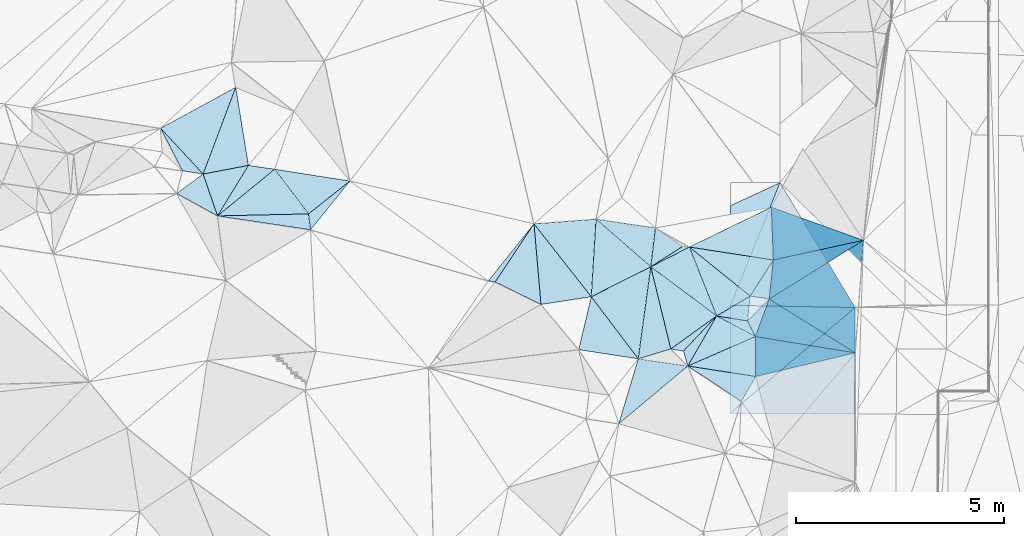
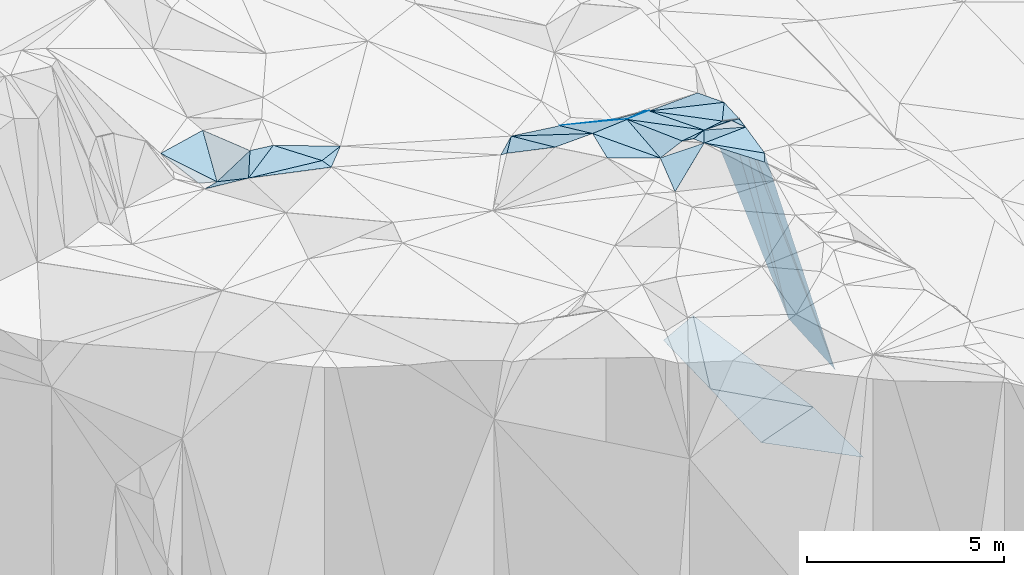
# One storey, part 126 of 275: 45 plates.
"""IFC2X3 building model written with IfcOpenShell, lengths in millimetres."""

from ifc_helpers import new_model, si_unit, frame, origin_with_axes, place, context, subcontext, project, spatial, polyline, outline, extrude, material, type_object, element, save


model = new_model("IFC2X3")

# Units and contexts
model_context = context("Model", 3, precision=1e-05, world=origin_with_axes())
body_context = subcontext(model_context, "Body", "Model", "MODEL_VIEW")
ifc_project = project(units=[si_unit("LENGTHUNIT", "METRE", prefix="MILLI"), si_unit("AREAUNIT", "SQUARE_METRE"), si_unit("VOLUMEUNIT", "CUBIC_METRE"), si_unit("MASSUNIT", "GRAM", prefix="KILO"), si_unit("TIMEUNIT", "SECOND"), si_unit("PLANEANGLEUNIT", "RADIAN"), si_unit("SOLIDANGLEUNIT", "STERADIAN"), si_unit("THERMODYNAMICTEMPERATUREUNIT", "DEGREE_CELSIUS"), si_unit("LUMINOUSINTENSITYUNIT", "LUMEN")], contexts=[model_context])

# Site, building, storey
site_placement = place(None, origin_with_axes())
site = spatial("IfcSite", under=ifc_project, at=site_placement, CompositionType="ELEMENT")
building_placement = place(site_placement, origin_with_axes())
building = spatial("IfcBuilding", under=site, at=building_placement, Name="Undefined", CompositionType="ELEMENT")
storey_placement = place(building_placement, origin_with_axes())
storey = spatial("IfcBuildingStorey", under=building, at=storey_placement, Name="Undefined", CompositionType="ELEMENT", Elevation=0.0)

# Plates
ifc_material = material()
plate_type_1 = type_object("IfcPlateType", PredefinedType="NOTDEFINED")
plate_1_placement = place(storey_placement, frame((-102975.586018144, 104495.460714109, 52899.5563168555), z_axis=(-0.102792415716425, -0.449545724247788, -0.887323143551273), x_axis=(-0.986264291093555, 0.162010960790731, 0.0321744727601088)))
element("IfcPlate", 1, at=plate_1_placement, inside=storey, type_object=plate_type_1, material=ifc_material, Name="00", context=body_context, shape_type="SweptSolid", body=[
    extrude(outline(polyline([(0.0, 0.0), (310.805419921875, -1.55705492943525e-09), (-665.689819335938, 1083.81591796875), (0.0, 0.0)])), frame((-8.85201319254618e-08, 2.18876761149539e-07, -0.5000001331573), z_axis=(0.0, 0.0, 1.0), x_axis=(1.0, 0.0, 0.0)), (0.0, 0.0, 1.0), 1.0),
])
plate_type_2 = type_object("IfcPlateType", PredefinedType="NOTDEFINED")
plate_2_placement = place(storey_placement, frame((-101853.013918243, 105596.241844771, 44075.3131280584), z_axis=(0.00903345976008048, 0.0208217817562675, -0.999742391823642), x_axis=(0.00396946090969268, 0.999774561543775, 0.0208583189648398)))
element("IfcPlate", 2, at=plate_2_placement, inside=storey, type_object=plate_type_2, material=ifc_material, Name="00_PR", context=body_context, shape_type="SweptSolid", body=[
    extrude(outline(polyline([(0.0, 0.0), (2396.74169921875, -1.78988557308912e-09), (2952.07104492188, 1186.95153808594), (0.0, 0.0)])), frame((-8.85201319254618e-08, 2.18876761149539e-07, -0.5000001331573), z_axis=(0.0, 0.0, 1.0), x_axis=(1.0, 0.0, 0.0)), (0.0, 0.0, 1.0), 1.0),
])
plate_type_3 = type_object("IfcPlateType", PredefinedType="NOTDEFINED")
plate_3_placement = place(storey_placement, frame((-112801.754794519, 108865.68811767, 53489.5226366196), z_axis=(-0.276028547930736, -0.111351786075685, -0.954677443152924), x_axis=(0.954406350382673, -0.149203927816331, -0.258547299876455)))
element("IfcPlate", 3, at=plate_3_placement, inside=storey, type_object=plate_type_3, material=ifc_material, Name="00", context=body_context, shape_type="SweptSolid", body=[
    extrude(outline(polyline([(0.0, 0.0), (1895.20446777344, -1.19907781481743e-08), (964.645263671875, 945.388549804688), (0.0, 0.0)])), frame((-8.85201319254618e-08, 2.18876761149539e-07, -0.5000001331573), z_axis=(0.0, 0.0, 1.0), x_axis=(1.0, 0.0, 0.0)), (0.0, 0.0, 1.0), 1.0),
])
plate_type_4 = type_object("IfcPlateType", PredefinedType="NOTDEFINED")
plate_4_placement = place(storey_placement, frame((-98853.4322599263, 105542.573777714, 42488.4351363047), z_axis=(-0.466934488972432, 0.0316275710281692, -0.883726133911922), x_axis=(-0.713003054106607, -0.604596175183413, 0.355091692085634)))
element("IfcPlate", 4, at=plate_4_placement, inside=storey, type_object=plate_type_4, material=ifc_material, Name="00_PR", context=body_context, shape_type="SweptSolid", body=[
    extrude(outline(polyline([(0.0, 0.0), (4220.29296875, 4.04543243348598e-09), (2669.9375, 2095.61401367188), (0.0, 0.0)])), frame((-8.85201319254618e-08, 2.18876761149539e-07, -0.5000001331573), z_axis=(0.0, 0.0, 1.0), x_axis=(1.0, 0.0, 0.0)), (0.0, 0.0, 1.0), 1.0),
])
plate_type_5 = type_object("IfcPlateType", PredefinedType="NOTDEFINED")
plate_5_placement = place(storey_placement, frame((-100654.633836518, 108542.806173912, 44147.576769315), z_axis=(-0.454677368979055, 0.20619155195464, -0.866460347644842), x_axis=(0.465101733246503, -0.774687277284736, -0.428415686155701)))
element("IfcPlate", 5, at=plate_5_placement, inside=storey, type_object=plate_type_5, material=ifc_material, Name="00_PR", context=body_context, shape_type="SweptSolid", body=[
    extrude(outline(polyline([(0.0, 0.0), (3872.7177734375, 2.44217517320067e-08), (1756.04797363281, 2653.27612304688), (0.0, 0.0)])), frame((-8.85201319254618e-08, 2.18876761149539e-07, -0.5000001331573), z_axis=(0.0, 0.0, 1.0), x_axis=(1.0, 0.0, 0.0)), (0.0, 0.0, 1.0), 1.0),
])
plate_type_6 = type_object("IfcPlateType", PredefinedType="NOTDEFINED")
plate_6_placement = place(storey_placement, frame((-102178.92224237, 105339.723863328, 52379.5387091909), z_axis=(-0.125325743835825, -0.364986820406231, -0.922538930810916), x_axis=(0.880317036051721, -0.469736537772759, 0.0662533102446467)))
element("IfcPlate", 6, at=plate_6_placement, inside=storey, type_object=plate_type_6, material=ifc_material, Name="00", context=body_context, shape_type="SweptSolid", body=[
    extrude(outline(polyline([(0.0, 0.0), (1056.55102539063, -2.5465851649642e-11), (-7.0985689163208, 1500.5498046875), (0.0, 0.0)])), frame((-8.85201319254618e-08, 2.18876761149539e-07, -0.5000001331573), z_axis=(0.0, 0.0, 1.0), x_axis=(1.0, 0.0, 0.0)), (0.0, 0.0, 1.0), 1.0),
])
plate_type_7 = type_object("IfcPlateType", PredefinedType="NOTDEFINED")
plate_7_placement = place(storey_placement, frame((-101862.504233261, 102990.985969973, 43987.020784836), z_axis=(-0.447209093222045, 0.00208047033283015, -0.894427022502513), x_axis=(0.713003054110074, 0.604596175166319, -0.355091692107778)))
element("IfcPlate", 7, at=plate_7_placement, inside=storey, type_object=plate_type_7, material=ifc_material, Name="00_PR", context=body_context, shape_type="SweptSolid", body=[
    extrude(outline(polyline([(0.0, 0.0), (4220.29296875, 4.04543243348598e-09), (2665.57739257813, 2035.8525390625), (0.0, 0.0)])), frame((-8.85201319254618e-08, 2.18876761149539e-07, -0.5000001331573), z_axis=(0.0, 0.0, 1.0), x_axis=(1.0, 0.0, 0.0)), (0.0, 0.0, 1.0), 1.0),
])
plate_type_8 = type_object("IfcPlateType", PredefinedType="NOTDEFINED")
plate_8_placement = place(storey_placement, frame((-107503.776969754, 106156.341462293, 53029.5442880401), z_axis=(-0.00890206486978785, -0.411474869166373, -0.911377630450501), x_axis=(-0.98622114632155, 0.154177586781641, -0.0599760142256649)))
element("IfcPlate", 8, at=plate_8_placement, inside=storey, type_object=plate_type_8, material=ifc_material, Name="00", context=body_context, shape_type="SweptSolid", body=[
    extrude(outline(polyline([(0.0, 0.0), (166.733322143555, 1.01863406598568e-09), (-668.1328125, 1670.20910644531), (0.0, 0.0)])), frame((-8.85201319254618e-08, 2.18876761149539e-07, -0.5000001331573), z_axis=(0.0, 0.0, 1.0), x_axis=(1.0, 0.0, 0.0)), (0.0, 0.0, 1.0), 1.0),
])
plate_type_9 = type_object("IfcPlateType", PredefinedType="NOTDEFINED")
plate_9_placement = place(storey_placement, frame((-100864.010065368, 107954.721490375, 51489.5375137855), z_axis=(-0.16714290473019, -0.341427049613979, -0.924927466988762), x_axis=(0.0349844372032486, -0.939587425435422, 0.340516606228254)))
element("IfcPlate", 9, at=plate_9_placement, inside=storey, type_object=plate_type_9, material=ifc_material, Name="00", context=body_context, shape_type="SweptSolid", body=[
    extrude(outline(polyline([(0.0, 0.0), (1350.88854980469, 4.65661287307739e-09), (1073.58959960938, 2038.1376953125), (0.0, 0.0)])), frame((-8.85201319254618e-08, 2.18876761149539e-07, -0.5000001331573), z_axis=(0.0, 0.0, 1.0), x_axis=(1.0, 0.0, 0.0)), (0.0, 0.0, 1.0), 1.0),
])
plate_type_10 = type_object("IfcPlateType", PredefinedType="NOTDEFINED")
plate_10_placement = place(storey_placement, frame((-102178.986117161, 105339.804867962, 52379.5270201422), z_axis=(-0.253064811166351, -0.202982983083332, -0.945915487730236), x_axis=(-0.798519126578451, 0.595827278124795, 0.0857733008038458)))
element("IfcPlate", 10, at=plate_10_placement, inside=storey, type_object=plate_type_10, material=ifc_material, Name="00", context=body_context, shape_type="SweptSolid", body=[
    extrude(outline(polyline([(0.0, 0.0), (1981.96875, 7.83984432928264e-09), (1495.02868652344, 985.184936523438), (0.0, 0.0)])), frame((-8.85201319254618e-08, 2.18876761149539e-07, -0.5000001331573), z_axis=(0.0, 0.0, 1.0), x_axis=(1.0, 0.0, 0.0)), (0.0, 0.0, 1.0), 1.0),
])
plate_type_11 = type_object("IfcPlateType", PredefinedType="NOTDEFINED")
plate_11_placement = place(storey_placement, frame((-102178.772572303, 105340.001274432, 52379.5168415305), z_axis=(0.174017111612536, 0.1898330364787, -0.966271940567099), x_axis=(0.976716766778855, -0.158295463721117, 0.144799529206335)))
element("IfcPlate", 11, at=plate_11_placement, inside=storey, type_object=plate_type_11, material=ifc_material, Name="00", context=body_context, shape_type="SweptSolid", body=[
    extrude(outline(polyline([(0.0, 0.0), (759.670959472656, -4.74392436444759e-09), (997.142211914063, 349.295593261719), (0.0, 0.0)])), frame((-8.85201319254618e-08, 2.18876761149539e-07, -0.5000001331573), z_axis=(0.0, 0.0, 1.0), x_axis=(1.0, 0.0, 0.0)), (0.0, 0.0, 1.0), 1.0),
])
plate_type_12 = type_object("IfcPlateType", PredefinedType="NOTDEFINED")
plate_12_placement = place(storey_placement, frame((-101249.026255045, 104843.516415534, 52449.5864675989), z_axis=(-0.533022787017966, -0.178672710709116, -0.827020417503375), x_axis=(-0.445378612206362, 0.890319763857286, 0.0947027448083864)))
element("IfcPlate", 12, at=plate_12_placement, inside=storey, type_object=plate_type_12, material=ifc_material, Name="00", context=body_context, shape_type="SweptSolid", body=[
    extrude(outline(polyline([(0.0, 0.0), (422.374237060547, 4.07453626394272e-09), (615.56787109375, 845.089477539063), (0.0, 0.0)])), frame((-8.85201319254618e-08, 2.18876761149539e-07, -0.5000001331573), z_axis=(0.0, 0.0, 1.0), x_axis=(1.0, 0.0, 0.0)), (0.0, 0.0, 1.0), 1.0),
])
plate_type_13 = type_object("IfcPlateType", PredefinedType="NOTDEFINED")
plate_13_placement = place(storey_placement, frame((-105192.650780856, 105800.683675955, 53049.5167005314), z_axis=(-0.25460741250302, -0.0307640323592072, -0.966555037135247), x_axis=(0.598484419040716, -0.790100774658256, -0.132503456747066)))
element("IfcPlate", 13, at=plate_13_placement, inside=storey, type_object=plate_type_13, material=ifc_material, Name="00", context=body_context, shape_type="SweptSolid", body=[
    extrude(outline(polyline([(0.0, 0.0), (1886.74328613281, 5.34782884642482e-09), (807.264038085938, 1033.64636230469), (0.0, 0.0)])), frame((-8.85201319254618e-08, 2.18876761149539e-07, -0.5000001331573), z_axis=(0.0, 0.0, 1.0), x_axis=(1.0, 0.0, 0.0)), (0.0, 0.0, 1.0), 1.0),
])
plate_type_14 = type_object("IfcPlateType", PredefinedType="NOTDEFINED")
plate_14_placement = place(storey_placement, frame((-100915.436868337, 105745.702646118, 52039.8569479673), z_axis=(-0.933668414142042, 0.215484609254262, -0.286058867382261), x_axis=(0.255334220219669, -0.159576432988249, -0.953593098768841)))
element("IfcPlate", 14, at=plate_14_placement, inside=storey, type_object=plate_type_14, material=ifc_material, Name="00", context=body_context, shape_type="SweptSolid", body=[
    extrude(outline(polyline([(0.0, 0.0), (8106.1826171875, -2.36468622460961e-08), (-332.264892578125, 991.312255859375), (0.0, 0.0)])), frame((-8.85201319254618e-08, 2.18876761149539e-07, -0.5000001331573), z_axis=(0.0, 0.0, 1.0), x_axis=(1.0, 0.0, 0.0)), (0.0, 0.0, 1.0), 1.0),
])
plate_type_15 = type_object("IfcPlateType", PredefinedType="NOTDEFINED")
plate_15_placement = place(storey_placement, frame((-102834.682902746, 106996.114100032, 52199.5229708087), z_axis=(-0.228432603864762, -0.194111337478636, -0.95401222956198), x_axis=(0.776880583327375, -0.626928272980853, -0.0584593857833135)))
element("IfcPlate", 15, at=plate_15_placement, inside=storey, type_object=plate_type_15, material=ifc_material, Name="00", context=body_context, shape_type="SweptSolid", body=[
    extrude(outline(polyline([(0.0, 0.0), (1881.64819335938, 6.01539795752615e-09), (1537.26928710938, 917.879699707031), (0.0, 0.0)])), frame((-8.85201319254618e-08, 2.18876761149539e-07, -0.5000001331573), z_axis=(0.0, 0.0, 1.0), x_axis=(1.0, 0.0, 0.0)), (0.0, 0.0, 1.0), 1.0),
])
plate_type_16 = type_object("IfcPlateType", PredefinedType="NOTDEFINED")
plate_16_placement = place(storey_placement, frame((-104063.279943566, 104309.945645716, 52799.5045662288), z_axis=(0.114232426673304, -0.072259576346678, -0.990822641204028), x_axis=(0.982045723646454, -0.142499335704393, 0.123612847194453)))
element("IfcPlate", 16, at=plate_16_placement, inside=storey, type_object=plate_type_16, material=ifc_material, Name="00", context=body_context, shape_type="SweptSolid", body=[
    extrude(outline(polyline([(0.0, 0.0), (1213.46606445313, 7.15954229235649e-09), (-229.590255737305, 1616.19567871094), (0.0, 0.0)])), frame((-8.85201319254618e-08, 2.18876761149539e-07, -0.5000001331573), z_axis=(0.0, 0.0, 1.0), x_axis=(1.0, 0.0, 0.0)), (0.0, 0.0, 1.0), 1.0),
])
plate_type_17 = type_object("IfcPlateType", PredefinedType="NOTDEFINED")
plate_17_placement = place(storey_placement, frame((-104063.48654232, 104309.948361449, 52799.5240181021), z_axis=(-0.298973153769321, -0.0668246843024553, -0.951918859406149), x_axis=(-0.598484419049735, 0.790100774651807, 0.132503456744784)))
element("IfcPlate", 17, at=plate_17_placement, inside=storey, type_object=plate_type_17, material=ifc_material, Name="00", context=body_context, shape_type="SweptSolid", body=[
    extrude(outline(polyline([(0.0, 0.0), (1886.74328613281, 5.34782884642482e-09), (1533.01196289063, 1640.51037597656), (0.0, 0.0)])), frame((-8.85201319254618e-08, 2.18876761149539e-07, -0.5000001331573), z_axis=(0.0, 0.0, 1.0), x_axis=(1.0, 0.0, 0.0)), (0.0, 0.0, 1.0), 1.0),
])
plate_type_18 = type_object("IfcPlateType", PredefinedType="NOTDEFINED")
plate_18_placement = place(storey_placement, frame((-101372.819607444, 105816.515885702, 52089.5058397826), z_axis=(-0.133768523823438, -0.0736100433029638, -0.988275034370005), x_axis=(-0.776880583325242, 0.626928272983298, 0.0584593857854413)))
element("IfcPlate", 18, at=plate_18_placement, inside=storey, type_object=plate_type_18, material=ifc_material, Name="00", context=body_context, shape_type="SweptSolid", body=[
    extrude(outline(polyline([(0.0, 0.0), (1881.64819335938, 6.01539795752615e-09), (104.642303466797, 1035.92956542969), (0.0, 0.0)])), frame((-8.85201319254618e-08, 2.18876761149539e-07, -0.5000001331573), z_axis=(0.0, 0.0, 1.0), x_axis=(1.0, 0.0, 0.0)), (0.0, 0.0, 1.0), 1.0),
])
plate_type_19 = type_object("IfcPlateType", PredefinedType="NOTDEFINED")
plate_19_placement = place(storey_placement, frame((-111988.454744971, 107792.934759834, 53379.5035642637), z_axis=(-0.112588733412213, -0.0403390438224003, -0.99282251115299), x_axis=(0.126899613227366, -0.99157742881999, 0.0258976990769921)))
element("IfcPlate", 19, at=plate_19_placement, inside=storey, type_object=plate_type_19, material=ifc_material, Name="00", context=body_context, shape_type="SweptSolid", body=[
    extrude(outline(polyline([(0.0, 0.0), (386.134704589844, -2.47382558882236e-09), (-222.979187011719, 2190.61181640625), (0.0, 0.0)])), frame((-8.85201319254618e-08, 2.18876761149539e-07, -0.5000001331573), z_axis=(0.0, 0.0, 1.0), x_axis=(1.0, 0.0, 0.0)), (0.0, 0.0, 1.0), 1.0),
])
plate_type_20 = type_object("IfcPlateType", PredefinedType="NOTDEFINED")
plate_20_placement = place(storey_placement, frame((-103761.637938682, 106520.6988983, 52549.5343605273), z_axis=(-0.276852035140459, -0.236975882224853, -0.931233258578289), x_axis=(0.7985191265766, -0.595827278127775, -0.0857733008003766)))
element("IfcPlate", 20, at=plate_20_placement, inside=storey, type_object=plate_type_20, material=ifc_material, Name="00", context=body_context, shape_type="SweptSolid", body=[
    extrude(outline(polyline([(0.0, 0.0), (1981.96875, 7.83984432928264e-09), (1528.58117675781, 1386.59289550781), (0.0, 0.0)])), frame((-8.85201319254618e-08, 2.18876761149539e-07, -0.5000001331573), z_axis=(0.0, 0.0, 1.0), x_axis=(1.0, 0.0, 0.0)), (0.0, 0.0, 1.0), 1.0),
])
plate_type_21 = type_object("IfcPlateType", PredefinedType="NOTDEFINED")
plate_21_placement = place(storey_placement, frame((-102871.833296391, 104136.949529387, 52949.5458937656), z_axis=(-0.350893741063123, -0.22825768644416, -0.908169593777443), x_axis=(-0.275757447153432, 0.95201879682497, -0.132732968140394)))
element("IfcPlate", 21, at=plate_21_placement, inside=storey, type_object=plate_type_21, material=ifc_material, Name="00", context=body_context, shape_type="SweptSolid", body=[
    extrude(outline(polyline([(0.0, 0.0), (376.696166992188, 6.98491930961609e-10), (1029.74230957031, 1091.48095703125), (0.0, 0.0)])), frame((-8.85201319254618e-08, 2.18876761149539e-07, -0.5000001331573), z_axis=(0.0, 0.0, 1.0), x_axis=(1.0, 0.0, 0.0)), (0.0, 0.0, 1.0), 1.0),
])
plate_type_22 = type_object("IfcPlateType", PredefinedType="NOTDEFINED")
plate_22_placement = place(storey_placement, frame((-111939.553481389, 107410.040215752, 53389.5258245765), z_axis=(-0.310744247441012, -0.0645356728375421, -0.948300142156335), x_axis=(-0.126899613196372, 0.991577428823402, -0.0258976990982327)))
element("IfcPlate", 22, at=plate_22_placement, inside=storey, type_object=plate_type_22, material=ifc_material, Name="00", context=body_context, shape_type="SweptSolid", body=[
    extrude(outline(polyline([(0.0, 0.0), (386.134704589844, -2.47382558882236e-09), (1053.00048828125, 1146.73022460938), (0.0, 0.0)])), frame((-8.85201319254618e-08, 2.18876761149539e-07, -0.5000001331573), z_axis=(0.0, 0.0, 1.0), x_axis=(1.0, 0.0, 0.0)), (0.0, 0.0, 1.0), 1.0),
])
plate_type_23 = type_object("IfcPlateType", PredefinedType="NOTDEFINED")
plate_23_placement = place(storey_placement, frame((-114522.016426286, 108750.403862502, 53029.5375892213), z_axis=(-0.34665093799035, 0.156939629334512, -0.924771906977475), x_axis=(-0.636299386171786, 0.685026390771958, 0.35477025679072)))
element("IfcPlate", 23, at=plate_23_placement, inside=storey, type_object=plate_type_23, material=ifc_material, Name="00", context=body_context, shape_type="SweptSolid", body=[
    extrude(outline(polyline([(0.0, 0.0), (1606.67358398438, -1.20671757031232e-08), (950.784301757813, 2015.26904296875), (0.0, 0.0)])), frame((-8.85201319254618e-08, 2.18876761149539e-07, -0.5000001331573), z_axis=(0.0, 0.0, 1.0), x_axis=(1.0, 0.0, 0.0)), (0.0, 0.0, 1.0), 1.0),
])
plate_type_24 = type_object("IfcPlateType", PredefinedType="NOTDEFINED")
plate_24_placement = place(storey_placement, frame((-113737.759012375, 110835.263397876, 53089.5475629932), z_axis=(0.406474175435745, -0.126780690881378, -0.904823408806089), x_axis=(0.156948250169796, -0.965916334660535, 0.205846742030563)))
element("IfcPlate", 24, at=plate_24_placement, inside=storey, type_object=plate_type_24, material=ifc_material, Name="00", context=body_context, shape_type="SweptSolid", body=[
    extrude(outline(polyline([(0.0, 0.0), (1943.19323730469, -1.88447302207351e-09), (1878.55737304688, 1198.46655273438), (0.0, 0.0)])), frame((-8.85201319254618e-08, 2.18876761149539e-07, -0.5000001331573), z_axis=(0.0, 0.0, 1.0), x_axis=(1.0, 0.0, 0.0)), (0.0, 0.0, 1.0), 1.0),
])
plate_type_25 = type_object("IfcPlateType", PredefinedType="NOTDEFINED")
plate_25_placement = place(storey_placement, frame((-103650.00271889, 107455.457478297, 51929.5834919), z_axis=(0.00734830614669874, -0.553269290299745, -0.832970044364136), x_axis=(0.774510245050719, -0.523748552774776, 0.35471303017764)))
element("IfcPlate", 25, at=plate_25_placement, inside=storey, type_object=plate_type_25, material=ifc_material, Name="00", context=body_context, shape_type="SweptSolid", body=[
    extrude(outline(polyline([(0.0, 0.0), (845.754089355469, 6.14090822637081e-09), (623.230773925781, 939.405883789063), (0.0, 0.0)])), frame((-8.85201319254618e-08, 2.18876761149539e-07, -0.5000001331573), z_axis=(0.0, 0.0, 1.0), x_axis=(1.0, 0.0, 0.0)), (0.0, 0.0, 1.0), 1.0),
])
plate_type_26 = type_object("IfcPlateType", PredefinedType="NOTDEFINED")
plate_26_placement = place(storey_placement, frame((-112801.673726655, 108865.751554847, 53489.5032889842), z_axis=(-0.113890391943033, 0.0155232505182584, -0.993372038722859), x_axis=(0.602086694944652, -0.794266284500156, -0.0814412737924915)))
element("IfcPlate", 26, at=plate_26_placement, inside=storey, type_object=plate_type_26, material=ifc_material, Name="00", context=body_context, shape_type="SweptSolid", body=[
    extrude(outline(polyline([(0.0, 0.0), (1350.66650390625, -2.91038304567337e-11), (51.9743385314941, 1778.1728515625), (0.0, 0.0)])), frame((-8.85201319254618e-08, 2.18876761149539e-07, -0.5000001331573), z_axis=(0.0, 0.0, 1.0), x_axis=(1.0, 0.0, 0.0)), (0.0, 0.0, 1.0), 1.0),
])
plate_type_27 = type_object("IfcPlateType", PredefinedType="NOTDEFINED")
plate_27_placement = place(storey_placement, frame((-101436.860053044, 105219.3744927, 52489.5856381247), z_axis=(0.0322899430319178, -0.558791841315508, -0.828679092084638), x_axis=(-0.976716766780193, 0.158295463712407, -0.144799529206831)))
element("IfcPlate", 27, at=plate_27_placement, inside=storey, type_object=plate_type_27, material=ifc_material, Name="00", context=body_context, shape_type="SweptSolid", body=[
    extrude(outline(polyline([(0.0, 0.0), (759.670959472656, -4.74392436444759e-09), (89.7757110595703, 715.779541015625), (0.0, 0.0)])), frame((-8.85201319254618e-08, 2.18876761149539e-07, -0.5000001331573), z_axis=(0.0, 0.0, 1.0), x_axis=(1.0, 0.0, 0.0)), (0.0, 0.0, 1.0), 1.0),
])
plate_type_28 = type_object("IfcPlateType", PredefinedType="NOTDEFINED")
plate_28_placement = place(storey_placement, frame((-103761.593635793, 106520.553834496, 52549.585632276), z_axis=(-0.18823552131394, -0.527106334680478, -0.82868950787094), x_axis=(-0.732184269301116, 0.637684962971011, -0.239299151249334)))
element("IfcPlate", 28, at=plate_28_placement, inside=storey, type_object=plate_type_28, material=ifc_material, Name="00", context=body_context, shape_type="SweptSolid", body=[
    extrude(outline(polyline([(0.0, 0.0), (1796.9140625, 3.82351572625339e-09), (662.914306640625, 911.835876464844), (0.0, 0.0)])), frame((-8.85201319254618e-08, 2.18876761149539e-07, -0.5000001331573), z_axis=(0.0, 0.0, 1.0), x_axis=(1.0, 0.0, 0.0)), (0.0, 0.0, 1.0), 1.0),
])
plate_type_29 = type_object("IfcPlateType", PredefinedType="NOTDEFINED")
plate_29_placement = place(storey_placement, frame((-114175.343260551, 107744.274071703, 53629.5822102696), z_axis=(0.420538135038801, -0.353611399359849, -0.835527770466581), x_axis=(-0.283529768114571, 0.823574818098121, -0.491258984230869)))
element("IfcPlate", 29, at=plate_29_placement, inside=storey, type_object=plate_type_29, material=ifc_material, Name="00", context=body_context, shape_type="SweptSolid", body=[
    extrude(outline(polyline([(0.0, 0.0), (1221.35168457031, -7.67613528296351e-09), (857.983825683594, 1143.88098144531), (0.0, 0.0)])), frame((-8.85201319254618e-08, 2.18876761149539e-07, -0.5000001331573), z_axis=(0.0, 0.0, 1.0), x_axis=(1.0, 0.0, 0.0)), (0.0, 0.0, 1.0), 1.0),
])
plate_type_30 = type_object("IfcPlateType", PredefinedType="NOTDEFINED")
plate_30_placement = place(storey_placement, frame((-114175.561249071, 107744.398260911, 53629.502810299), z_axis=(-0.0154374702091968, -0.105231910170981, -0.994327878315451), x_axis=(0.519319259040148, 0.848953049399609, -0.0979092799743556)))
element("IfcPlate", 30, at=plate_30_placement, inside=storey, type_object=plate_type_30, material=ifc_material, Name="00", context=body_context, shape_type="SweptSolid", body=[
    extrude(outline(polyline([(0.0, 0.0), (1429.89514160156, -1.28638930618763e-08), (1679.14416503906, 587.430786132813), (0.0, 0.0)])), frame((-8.85201319254618e-08, 2.18876761149539e-07, -0.5000001331573), z_axis=(0.0, 0.0, 1.0), x_axis=(1.0, 0.0, 0.0)), (0.0, 0.0, 1.0), 1.0),
])
plate_type_31 = type_object("IfcPlateType", PredefinedType="NOTDEFINED")
plate_31_placement = place(storey_placement, frame((-114175.554364671, 107744.194528358, 53629.5706916161), z_axis=(-0.00165966156592223, -0.512701901165173, -0.85856508551484), x_axis=(-0.842846558152991, 0.462756461858967, -0.27471100527177)))
element("IfcPlate", 31, at=plate_31_placement, inside=storey, type_object=plate_type_31, material=ifc_material, Name="00", context=body_context, shape_type="SweptSolid", body=[
    extrude(outline(polyline([(0.0, 0.0), (1164.86047363281, -3.63797880709171e-11), (922.170532226563, 800.813049316406), (0.0, 0.0)])), frame((-8.85201319254618e-08, 2.18876761149539e-07, -0.5000001331573), z_axis=(0.0, 0.0, 1.0), x_axis=(1.0, 0.0, 0.0)), (0.0, 0.0, 1.0), 1.0),
])
plate_type_32 = type_object("IfcPlateType", PredefinedType="NOTDEFINED")
plate_32_placement = place(storey_placement, frame((-106401.186967746, 105616.060993357, 53159.5377129538), z_axis=(-0.0741776147671011, -0.373827046320769, -0.924527458167984), x_axis=(-0.892994833766598, 0.437578966621113, -0.105284732212062)))
element("IfcPlate", 32, at=plate_32_placement, inside=storey, type_object=plate_type_32, material=ifc_material, Name="00", context=body_context, shape_type="SweptSolid", body=[
    extrude(outline(polyline([(0.0, 0.0), (1234.74694824219, 2.16095941141248e-09), (1078.76354980469, 1792.11303710938), (0.0, 0.0)])), frame((-8.85201319254618e-08, 2.18876761149539e-07, -0.5000001331573), z_axis=(0.0, 0.0, 1.0), x_axis=(1.0, 0.0, 0.0)), (0.0, 0.0, 1.0), 1.0),
])
plate_type_33 = type_object("IfcPlateType", PredefinedType="NOTDEFINED")
plate_33_placement = place(storey_placement, frame((-106569.003709686, 107553.643540101, 52389.5546008518), z_axis=(-0.128244444530515, -0.436020205729038, -0.890752346414573), x_axis=(0.981298834421895, 0.0742146342707431, -0.177608517876507)))
element("IfcPlate", 33, at=plate_33_placement, inside=storey, type_object=plate_type_33, material=ifc_material, Name="00", context=body_context, shape_type="SweptSolid", body=[
    extrude(outline(polyline([(0.0, 0.0), (1520.19738769531, 8.14907252788544e-09), (1103.34362792969, 2046.05297851563), (0.0, 0.0)])), frame((-8.85201319254618e-08, 2.18876761149539e-07, -0.5000001331573), z_axis=(0.0, 0.0, 1.0), x_axis=(1.0, 0.0, 0.0)), (0.0, 0.0, 1.0), 1.0),
])
plate_type_34 = type_object("IfcPlateType", PredefinedType="NOTDEFINED")
plate_34_placement = place(storey_placement, frame((-103761.410561955, 106520.750125212, 52549.5125722988), z_axis=(0.177895103047355, -0.134518539932079, -0.97481182529056), x_axis=(0.232305736061169, -0.956872925443488, 0.174436950060186)))
element("IfcPlate", 34, at=plate_34_placement, inside=storey, type_object=plate_type_34, material=ifc_material, Name="00", context=body_context, shape_type="SweptSolid", body=[
    extrude(outline(polyline([(0.0, 0.0), (2063.78295898438, -7.36326910555363e-09), (2088.9794921875, 823.143432617188), (0.0, 0.0)])), frame((-8.85201319254618e-08, 2.18876761149539e-07, -0.5000001331573), z_axis=(0.0, 0.0, 1.0), x_axis=(1.0, 0.0, 0.0)), (0.0, 0.0, 1.0), 1.0),
])
plate_type_35 = type_object("IfcPlateType", PredefinedType="NOTDEFINED")
plate_35_placement = place(storey_placement, frame((-100816.726803244, 106685.573222361, 51949.5053377258), z_axis=(-0.120774910427692, -0.0820861876453556, -0.989280182157226), x_axis=(-0.103540609728364, -0.990097631775724, 0.0947946290101987)))
element("IfcPlate", 35, at=plate_35_placement, inside=storey, type_object=plate_type_35, material=ifc_material, Name="00", context=body_context, shape_type="SweptSolid", body=[
    extrude(outline(polyline([(0.0, 0.0), (949.4208984375, 2.38651409745216e-09), (931.304565429688, 465.587585449219), (0.0, 0.0)])), frame((-8.85201319254618e-08, 2.18876761149539e-07, -0.5000001331573), z_axis=(0.0, 0.0, 1.0), x_axis=(1.0, 0.0, 0.0)), (0.0, 0.0, 1.0), 1.0),
])
plate_type_36 = type_object("IfcPlateType", PredefinedType="NOTDEFINED")
plate_36_placement = place(storey_placement, frame((-102871.865702827, 104137.03250315, 52949.5462959173), z_axis=(-0.415699511207915, -0.0623108126376355, -0.907365019719153), x_axis=(0.90382346710793, -0.139611384815051, -0.404489556768804)))
element("IfcPlate", 36, at=plate_36_placement, inside=storey, type_object=plate_type_36, material=ifc_material, Name="00", context=body_context, shape_type="SweptSolid", body=[
    extrude(outline(polyline([(0.0, 0.0), (1804.74377441406, 1.06665538623929e-08), (1494.72741699219, 652.372497558594), (0.0, 0.0)])), frame((-8.85201319254618e-08, 2.18876761149539e-07, -0.5000001331573), z_axis=(0.0, 0.0, 1.0), x_axis=(1.0, 0.0, 0.0)), (0.0, 0.0, 1.0), 1.0),
])
plate_type_37 = type_object("IfcPlateType", PredefinedType="NOTDEFINED")
plate_37_placement = place(storey_placement, frame((-100817.142554628, 106685.546910928, 51949.8630439091), z_axis=(-0.952286106583891, -0.134710372181244, -0.273869105293176), x_axis=(-0.0349844372001138, 0.939587425435861, -0.340516606227364)))
element("IfcPlate", 37, at=plate_37_placement, inside=storey, type_object=plate_type_37, material=ifc_material, Name="00", context=body_context, shape_type="SweptSolid", body=[
    extrude(outline(polyline([(0.0, 0.0), (1350.88854980469, 4.65661287307739e-09), (3012.15063476563, 7490.32373046875), (0.0, 0.0)])), frame((-8.85201319254618e-08, 2.18876761149539e-07, -0.5000001331573), z_axis=(0.0, 0.0, 1.0), x_axis=(1.0, 0.0, 0.0)), (0.0, 0.0, 1.0), 1.0),
])
plate_type_38 = type_object("IfcPlateType", PredefinedType="NOTDEFINED")
plate_38_placement = place(storey_placement, frame((-101248.945430958, 104843.712557492, 52449.5481918675), z_axis=(-0.371381270280084, 0.213613906363476, -0.903573489591902), x_axis=(0.00839123126731934, -0.972362543718762, -0.233325246834966)))
element("IfcPlate", 38, at=plate_38_placement, inside=storey, type_object=plate_type_38, material=ifc_material, Name="00", context=body_context, shape_type="SweptSolid", body=[
    extrude(outline(polyline([(0.0, 0.0), (985.748474121094, 6.69388100504875e-09), (556.734313964844, 1753.01086425781), (0.0, 0.0)])), frame((-8.85201319254618e-08, 2.18876761149539e-07, -0.5000001331573), z_axis=(0.0, 0.0, 1.0), x_axis=(1.0, 0.0, 0.0)), (0.0, 0.0, 1.0), 1.0),
])
plate_type_39 = type_object("IfcPlateType", PredefinedType="NOTDEFINED")
plate_39_placement = place(storey_placement, frame((-100915.451020561, 105745.623339274, 52039.8664279436), z_axis=(-0.961989205933761, 0.0568731109024855, -0.267099638568094), x_axis=(0.272960026238927, 0.170372272008898, -0.946818944152561)))
element("IfcPlate", 39, at=plate_39_placement, inside=storey, type_object=plate_type_39, material=ifc_material, Name="00", context=body_context, shape_type="SweptSolid", body=[
    extrude(outline(polyline([(0.0, 0.0), (8294.087890625, -9.34232957661152e-09), (7663.4931640625, 2642.171875), (0.0, 0.0)])), frame((-8.85201319254618e-08, 2.18876761149539e-07, -0.5000001331573), z_axis=(0.0, 0.0, 1.0), x_axis=(1.0, 0.0, 0.0)), (0.0, 0.0, 1.0), 1.0),
])
plate_type_40 = type_object("IfcPlateType", PredefinedType="NOTDEFINED")
plate_40_placement = place(storey_placement, frame((-101240.966367947, 103885.130994432, 52219.8573073594), z_axis=(-0.956532597688299, 0.0602149860540438, -0.285341102917518), x_axis=(-0.00839123128550632, 0.972362543719863, 0.233325246829721)))
element("IfcPlate", 40, at=plate_40_placement, inside=storey, type_object=plate_type_40, material=ifc_material, Name="00", context=body_context, shape_type="SweptSolid", body=[
    extrude(outline(polyline([(0.0, 0.0), (985.748474121094, 6.69388100504875e-09), (-1314.43273925781, 8179.197265625), (0.0, 0.0)])), frame((-8.85201319254618e-08, 2.18876761149539e-07, -0.5000001331573), z_axis=(0.0, 0.0, 1.0), x_axis=(1.0, 0.0, 0.0)), (0.0, 0.0, 1.0), 1.0),
])
plate_type_41 = type_object("IfcPlateType", PredefinedType="NOTDEFINED")
plate_41_placement = place(storey_placement, frame((-106568.95349315, 107553.675927333, 52389.5359164763), z_axis=(-0.0278147069986641, -0.371239968523979, -0.928120265830293), x_axis=(0.592112364956741, -0.754182679636993, 0.283921526131607)))
element("IfcPlate", 41, at=plate_41_placement, inside=storey, type_object=plate_type_41, material=ifc_material, Name="00", context=body_context, shape_type="SweptSolid", body=[
    extrude(outline(polyline([(0.0, 0.0), (2324.5859375, 3.56521923094988e-09), (1779.28454589844, 1099.79382324219), (0.0, 0.0)])), frame((-8.85201319254618e-08, 2.18876761149539e-07, -0.5000001331573), z_axis=(0.0, 0.0, 1.0), x_axis=(1.0, 0.0, 0.0)), (0.0, 0.0, 1.0), 1.0),
])
plate_type_42 = type_object("IfcPlateType", PredefinedType="NOTDEFINED")
plate_42_placement = place(storey_placement, frame((-105077.217157164, 107666.462580924, 52119.553213796), z_axis=(-0.0909279829782739, -0.439709201750896, -0.893525556325667), x_axis=(0.732184269269903, -0.637684962995917, 0.239299151278465)))
element("IfcPlate", 42, at=plate_42_placement, inside=storey, type_object=plate_type_42, material=ifc_material, Name="00", context=body_context, shape_type="SweptSolid", body=[
    extrude(outline(polyline([(0.0, 0.0), (1796.9140625, 3.82351572625339e-09), (1327.9990234375, 1611.37170410156), (0.0, 0.0)])), frame((-8.85201319254618e-08, 2.18876761149539e-07, -0.5000001331573), z_axis=(0.0, 0.0, 1.0), x_axis=(1.0, 0.0, 0.0)), (0.0, 0.0, 1.0), 1.0),
])
plate_type_43 = type_object("IfcPlateType", PredefinedType="NOTDEFINED")
plate_43_placement = place(storey_placement, frame((-115544.211995824, 109851.13582685, 53599.5423211522), z_axis=(-0.0869569053091922, 0.39325909231114, -0.915306387464693), x_axis=(0.636299386167017, -0.685026390779125, -0.354770256785434)))
element("IfcPlate", 43, at=plate_43_placement, inside=storey, type_object=plate_type_43, material=ifc_material, Name="00", context=body_context, shape_type="SweptSolid", body=[
    extrude(outline(polyline([(0.0, 0.0), (1606.67358398438, -1.20671757031232e-08), (1211.57153320313, 315.585784912109), (0.0, 0.0)])), frame((-8.85201319254618e-08, 2.18876761149539e-07, -0.5000001331573), z_axis=(0.0, 0.0, 1.0), x_axis=(1.0, 0.0, 0.0)), (0.0, 0.0, 1.0), 1.0),
])
plate_type_44 = type_object("IfcPlateType", PredefinedType="NOTDEFINED")
plate_44_placement = place(storey_placement, frame((-103761.601898926, 106520.672784685, 52549.5324214384), z_axis=(-0.204764511430895, -0.289204897542957, -0.935110700449757), x_axis=(0.794009915931286, 0.509585134181731, -0.331468315867113)))
element("IfcPlate", 44, at=plate_44_placement, inside=storey, type_object=plate_type_44, material=ifc_material, Name="00", context=body_context, shape_type="SweptSolid", body=[
    extrude(outline(polyline([(0.0, 0.0), (965.401489257813, 1.65891833603382e-09), (1094.259765625, 101.466926574707), (0.0, 0.0)])), frame((-8.85201319254618e-08, 2.18876761149539e-07, -0.5000001331573), z_axis=(0.0, 0.0, 1.0), x_axis=(1.0, 0.0, 0.0)), (0.0, 0.0, 1.0), 1.0),
])
plate_type_45 = type_object("IfcPlateType", PredefinedType="NOTDEFINED")
plate_45_placement = place(storey_placement, frame((-100915.450863108, 105745.632564917, 52039.8681344128), z_axis=(-0.961663330549806, 0.0753210344051247, -0.263686140045313), x_axis=(0.103540609737854, 0.990097631774882, -0.0947946290086317)))
element("IfcPlate", 45, at=plate_45_placement, inside=storey, type_object=plate_type_45, material=ifc_material, Name="00", context=body_context, shape_type="SweptSolid", body=[
    extrude(outline(polyline([(0.0, 0.0), (949.4208984375, 2.38651409745216e-09), (2377.92333984375, 7945.9033203125), (0.0, 0.0)])), frame((-8.85201319254618e-08, 2.18876761149539e-07, -0.5000001331573), z_axis=(0.0, 0.0, 1.0), x_axis=(1.0, 0.0, 0.0)), (0.0, 0.0, 1.0), 1.0),
])

save(model, "model.ifc")
